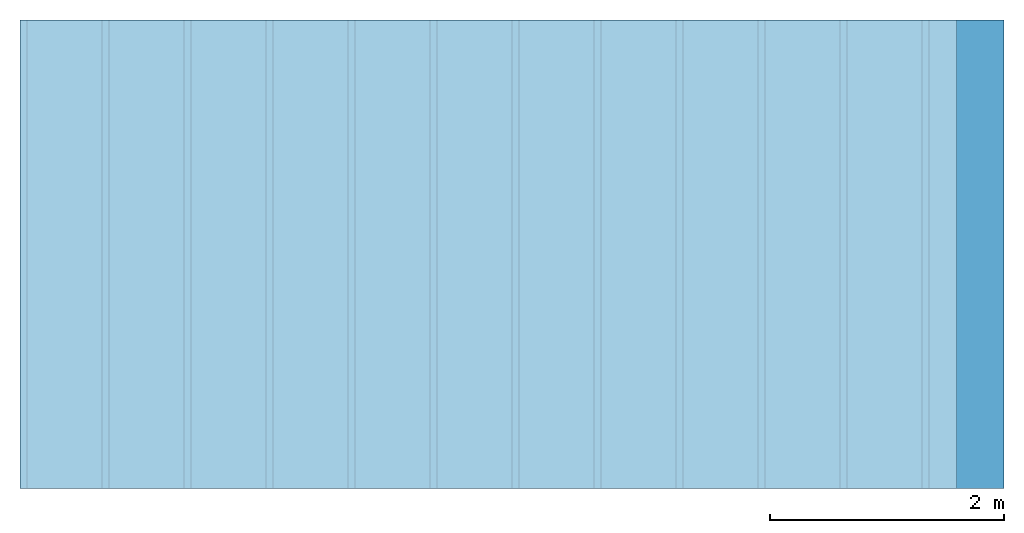
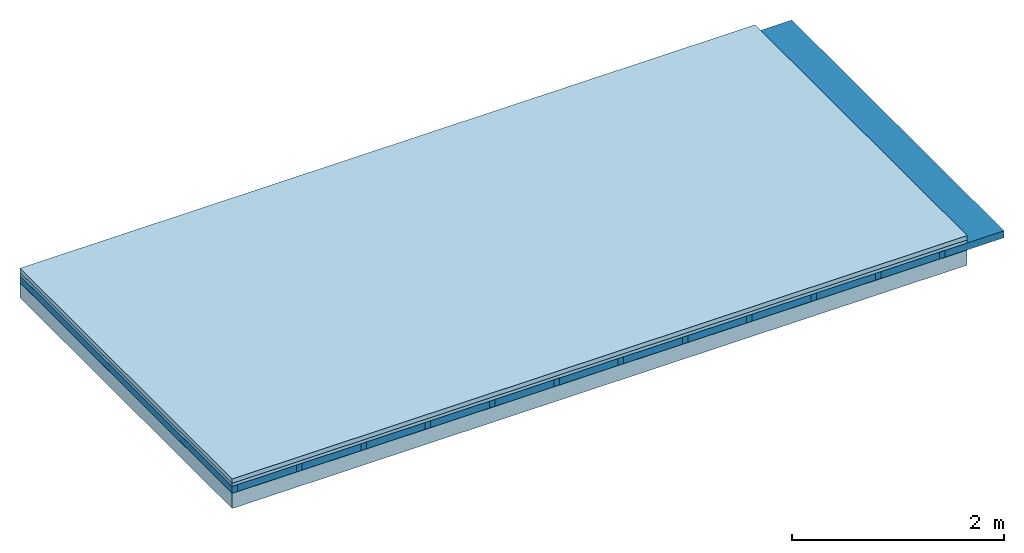
# One storey: 4 plates, 2 members, 1 element without a shape of its own.
"""IFC4 building model written with IfcOpenShell, lengths in metres."""

from ifc_helpers import new_model, si_unit, derived_unit, direction, frame, frame_2d, origin, origin_with_axes, place, context, project, spatial, rectangle, extrude, material, layer, layer_set, type_object, element, aggregate, save


model = new_model("IFC4")

# Units and contexts
plan_context = context("Plan", 3, precision=1e-05, world=origin(), true_north=direction((0.0, 1.0)))
model_context = context("Model", 3, precision=1e-05, world=origin(), true_north=direction((0.0, 1.0)))
ifc_project = project(units=[si_unit("LENGTHUNIT", "METRE"), derived_unit("SOUNDPRESSUREUNIT", [(si_unit("PRESSUREUNIT", "PASCAL", prefix="MICRO"), 0)]), si_unit("ENERGYUNIT", "JOULE", prefix="MEGA"), si_unit("MASSUNIT", "GRAM", prefix="KILO"), derived_unit("THERMALTRANSMITTANCEUNIT", [(si_unit("POWERUNIT", "WATT"), 1), (si_unit("AREAUNIT", "SQUARE_METRE"), -1), (si_unit("THERMODYNAMICTEMPERATUREUNIT", "KELVIN"), -1)]), derived_unit("AREADENSITYUNIT", [(si_unit("MASSUNIT", "GRAM", prefix="KILO"), 1), (si_unit("AREAUNIT", "SQUARE_METRE"), -1)]), derived_unit("USERDEFINED", [(si_unit("ENERGYUNIT", "JOULE", prefix="MEGA"), 1), (si_unit("AREAUNIT", "SQUARE_METRE"), -1)])], contexts=[plan_context, model_context])

# Site, building, storey
site = spatial("IfcSite", under=ifc_project)
building_placement = place(None, origin())
building = spatial("IfcBuilding", under=site, at=building_placement)
storey_placement = place(building_placement, origin())
storey = spatial("IfcBuildingStorey", under=building, at=storey_placement)

# Slab, members, plates
ifc_material_1 = material(Name="Cement screed", Category="04.006")
ifc_layer_1 = layer(ifc_material_1, 0.05, Name="On-material")
ifc_material_2 = material(Name="EP1, 40/35mm")
ifc_layer_2 = layer(ifc_material_2, 0.035, Name="Impact sound insulation")
ifc_material_3 = material(Name="no composite action")
ifc_layer_3 = layer(ifc_material_3, 0.0, Name="Bond")
ifc_layer_4 = layer(None, 0.08, Name="Supporting structure")
ifc_material_4 = material(Name="protection", Category="09.007")
ifc_layer_5 = layer(ifc_material_4, 0.0005, Name="Lower layer 1")
ifc_material_5 = material(Name="OSB", Category="07.013")
ifc_layer_6 = layer(ifc_material_5, 0.175, Name="Lower 2nd layer")
ifc_layer_set = layer_set([ifc_layer_1, ifc_layer_2, ifc_layer_3, ifc_layer_4, ifc_layer_5, ifc_layer_6])
slab_type = type_object("IfcSlabType", Name="A2715", PredefinedType="NOTDEFINED", material=ifc_layer_set)
slab_placement = place(None, frame((0.0, 0.0, 0.0), z_axis=(0.0, 0.0, -1.0), x_axis=(1.0, 0.0, 0.0)))
slab = element("IfcSlab", 1, at=slab_placement, inside=storey, type_object=slab_type, material=ifc_layer_set, Name="Slab #1")
ifc_material_6 = material()
member_1_placement = place(slab_placement, origin())
member_1 = element("IfcMember", 2, at=member_1_placement, material=ifc_material_6, Name="Supporting structure", context=plan_context, shape_type="SweptSolid", body=[
    extrude(rectangle(XDim=0.06, YDim=0.08, at=frame_2d((0.03, 0.04), x_axis=(1.0, 0.0))), frame((0.0, 4.0, 0.085), z_axis=(0.0, -1.0, 0.0), x_axis=(1.0, 0.0, 0.0)), (0.0, 0.0, 1.0), 4.0),
    extrude(rectangle(XDim=0.06, YDim=0.08, at=frame_2d((0.03, 0.04), x_axis=(1.0, 0.0))), frame((0.7, 4.0, 0.085), z_axis=(0.0, -1.0, 0.0), x_axis=(1.0, 0.0, 0.0)), (0.0, 0.0, 1.0), 4.0),
    extrude(rectangle(XDim=0.06, YDim=0.08, at=frame_2d((0.03, 0.04), x_axis=(1.0, 0.0))), frame((1.4, 4.0, 0.085), z_axis=(0.0, -1.0, 0.0), x_axis=(1.0, 0.0, 0.0)), (0.0, 0.0, 1.0), 4.0),
    extrude(rectangle(XDim=0.06, YDim=0.08, at=frame_2d((0.03, 0.04), x_axis=(1.0, 0.0))), frame((2.1, 4.0, 0.085), z_axis=(0.0, -1.0, 0.0), x_axis=(1.0, 0.0, 0.0)), (0.0, 0.0, 1.0), 4.0),
    extrude(rectangle(XDim=0.06, YDim=0.08, at=frame_2d((0.03, 0.04), x_axis=(1.0, 0.0))), frame((2.8, 4.0, 0.085), z_axis=(0.0, -1.0, 0.0), x_axis=(1.0, 0.0, 0.0)), (0.0, 0.0, 1.0), 4.0),
    extrude(rectangle(XDim=0.06, YDim=0.08, at=frame_2d((0.03, 0.04), x_axis=(1.0, 0.0))), frame((3.5, 4.0, 0.085), z_axis=(0.0, -1.0, 0.0), x_axis=(1.0, 0.0, 0.0)), (0.0, 0.0, 1.0), 4.0),
    extrude(rectangle(XDim=0.06, YDim=0.08, at=frame_2d((0.03, 0.04), x_axis=(1.0, 0.0))), frame((4.2, 4.0, 0.085), z_axis=(0.0, -1.0, 0.0), x_axis=(1.0, 0.0, 0.0)), (0.0, 0.0, 1.0), 4.0),
    extrude(rectangle(XDim=0.06, YDim=0.08, at=frame_2d((0.03, 0.04), x_axis=(1.0, 0.0))), frame((4.9, 4.0, 0.085), z_axis=(0.0, -1.0, 0.0), x_axis=(1.0, 0.0, 0.0)), (0.0, 0.0, 1.0), 4.0),
    extrude(rectangle(XDim=0.06, YDim=0.08, at=frame_2d((0.03, 0.04), x_axis=(1.0, 0.0))), frame((5.6, 4.0, 0.085), z_axis=(0.0, -1.0, 0.0), x_axis=(1.0, 0.0, 0.0)), (0.0, 0.0, 1.0), 4.0),
    extrude(rectangle(XDim=0.06, YDim=0.08, at=frame_2d((0.03, 0.04), x_axis=(1.0, 0.0))), frame((6.3, 4.0, 0.085), z_axis=(0.0, -1.0, 0.0), x_axis=(1.0, 0.0, 0.0)), (0.0, 0.0, 1.0), 4.0),
    extrude(rectangle(XDim=0.06, YDim=0.08, at=frame_2d((0.03, 0.04), x_axis=(1.0, 0.0))), frame((7.0, 4.0, 0.085), z_axis=(0.0, -1.0, 0.0), x_axis=(1.0, 0.0, 0.0)), (0.0, 0.0, 1.0), 4.0),
    extrude(rectangle(XDim=0.06, YDim=0.08, at=frame_2d((0.03, 0.04), x_axis=(1.0, 0.0))), frame((7.7, 4.0, 0.085), z_axis=(0.0, -1.0, 0.0), x_axis=(1.0, 0.0, 0.0)), (0.0, 0.0, 1.0), 4.0),
])
ifc_material_7 = material()
member_2_placement = place(slab_placement, origin())
member_2 = element("IfcMember", 3, at=member_2_placement, material=ifc_material_7, Name="in supporting structure", context=plan_context, shape_type="SweptSolid", body=[
    extrude(rectangle(XDim=0.64, YDim=0.08, at=frame_2d((0.32, 0.04), x_axis=(1.0, 0.0))), frame((0.06, 4.0, 0.085), z_axis=(0.0, -1.0, 0.0), x_axis=(1.0, 0.0, 0.0)), (0.0, 0.0, 1.0), 4.0),
    extrude(rectangle(XDim=0.64, YDim=0.08, at=frame_2d((0.32, 0.04), x_axis=(1.0, 0.0))), frame((0.76, 4.0, 0.085), z_axis=(0.0, -1.0, 0.0), x_axis=(1.0, 0.0, 0.0)), (0.0, 0.0, 1.0), 4.0),
    extrude(rectangle(XDim=0.64, YDim=0.08, at=frame_2d((0.32, 0.04), x_axis=(1.0, 0.0))), frame((1.46, 4.0, 0.085), z_axis=(0.0, -1.0, 0.0), x_axis=(1.0, 0.0, 0.0)), (0.0, 0.0, 1.0), 4.0),
    extrude(rectangle(XDim=0.64, YDim=0.08, at=frame_2d((0.32, 0.04), x_axis=(1.0, 0.0))), frame((2.16, 4.0, 0.085), z_axis=(0.0, -1.0, 0.0), x_axis=(1.0, 0.0, 0.0)), (0.0, 0.0, 1.0), 4.0),
    extrude(rectangle(XDim=0.64, YDim=0.08, at=frame_2d((0.32, 0.04), x_axis=(1.0, 0.0))), frame((2.86, 4.0, 0.085), z_axis=(0.0, -1.0, 0.0), x_axis=(1.0, 0.0, 0.0)), (0.0, 0.0, 1.0), 4.0),
    extrude(rectangle(XDim=0.64, YDim=0.08, at=frame_2d((0.32, 0.04), x_axis=(1.0, 0.0))), frame((3.56, 4.0, 0.085), z_axis=(0.0, -1.0, 0.0), x_axis=(1.0, 0.0, 0.0)), (0.0, 0.0, 1.0), 4.0),
    extrude(rectangle(XDim=0.64, YDim=0.08, at=frame_2d((0.32, 0.04), x_axis=(1.0, 0.0))), frame((4.26, 4.0, 0.085), z_axis=(0.0, -1.0, 0.0), x_axis=(1.0, 0.0, 0.0)), (0.0, 0.0, 1.0), 4.0),
    extrude(rectangle(XDim=0.64, YDim=0.08, at=frame_2d((0.32, 0.04), x_axis=(1.0, 0.0))), frame((4.96, 4.0, 0.085), z_axis=(0.0, -1.0, 0.0), x_axis=(1.0, 0.0, 0.0)), (0.0, 0.0, 1.0), 4.0),
    extrude(rectangle(XDim=0.64, YDim=0.08, at=frame_2d((0.32, 0.04), x_axis=(1.0, 0.0))), frame((5.66, 4.0, 0.085), z_axis=(0.0, -1.0, 0.0), x_axis=(1.0, 0.0, 0.0)), (0.0, 0.0, 1.0), 4.0),
    extrude(rectangle(XDim=0.64, YDim=0.08, at=frame_2d((0.32, 0.04), x_axis=(1.0, 0.0))), frame((6.36, 4.0, 0.085), z_axis=(0.0, -1.0, 0.0), x_axis=(1.0, 0.0, 0.0)), (0.0, 0.0, 1.0), 4.0),
    extrude(rectangle(XDim=0.64, YDim=0.08, at=frame_2d((0.32, 0.04), x_axis=(1.0, 0.0))), frame((7.06, 4.0, 0.085), z_axis=(0.0, -1.0, 0.0), x_axis=(1.0, 0.0, 0.0)), (0.0, 0.0, 1.0), 4.0),
    extrude(rectangle(XDim=0.64, YDim=0.08, at=frame_2d((0.32, 0.04), x_axis=(1.0, 0.0))), frame((7.76, 4.0, 0.085), z_axis=(0.0, -1.0, 0.0), x_axis=(1.0, 0.0, 0.0)), (0.0, 0.0, 1.0), 4.0),
])
plate_1_placement = place(slab_placement, origin())
plate_1 = element("IfcPlate", 4, at=plate_1_placement, material=ifc_material_1, Name="On-material", context=plan_context, shape_type="SweptSolid", body=[
    extrude(rectangle(XDim=8.0, YDim=4.0, at=frame_2d((4.0, 2.0), x_axis=(1.0, 0.0))), origin_with_axes(), (0.0, 0.0, 1.0), 0.05),
])
plate_2_placement = place(slab_placement, origin())
plate_2 = element("IfcPlate", 5, at=plate_2_placement, material=ifc_material_2, Name="Impact sound insulation", context=plan_context, shape_type="SweptSolid", body=[
    extrude(rectangle(XDim=8.0, YDim=4.0, at=frame_2d((4.0, 2.0), x_axis=(1.0, 0.0))), frame((0.0, 0.0, 0.05), z_axis=(0.0, 0.0, 1.0), x_axis=(1.0, 0.0, 0.0)), (0.0, 0.0, 1.0), 0.035),
])
plate_3_placement = place(slab_placement, origin())
plate_3 = element("IfcPlate", 6, at=plate_3_placement, material=ifc_material_4, Name="Lower layer 1", context=plan_context, shape_type="SweptSolid", body=[
    extrude(rectangle(XDim=8.0, YDim=4.0, at=frame_2d((4.0, 2.0), x_axis=(1.0, 0.0))), frame((0.0, 0.0, 0.165), z_axis=(0.0, 0.0, 1.0), x_axis=(1.0, 0.0, 0.0)), (0.0, 0.0, 1.0), 0.0005),
])
plate_4_placement = place(slab_placement, origin())
plate_4 = element("IfcPlate", 7, at=plate_4_placement, material=ifc_material_5, Name="Lower 2nd layer", context=plan_context, shape_type="SweptSolid", body=[
    extrude(rectangle(XDim=8.0, YDim=4.0, at=frame_2d((4.0, 2.0), x_axis=(1.0, 0.0))), frame((0.0, 0.0, 0.1655), z_axis=(0.0, 0.0, 1.0), x_axis=(1.0, 0.0, 0.0)), (0.0, 0.0, 1.0), 0.175),
])
aggregate(slab, [plate_1, plate_2, member_1, member_2, plate_3, plate_4])

save(model, "model.ifc")
